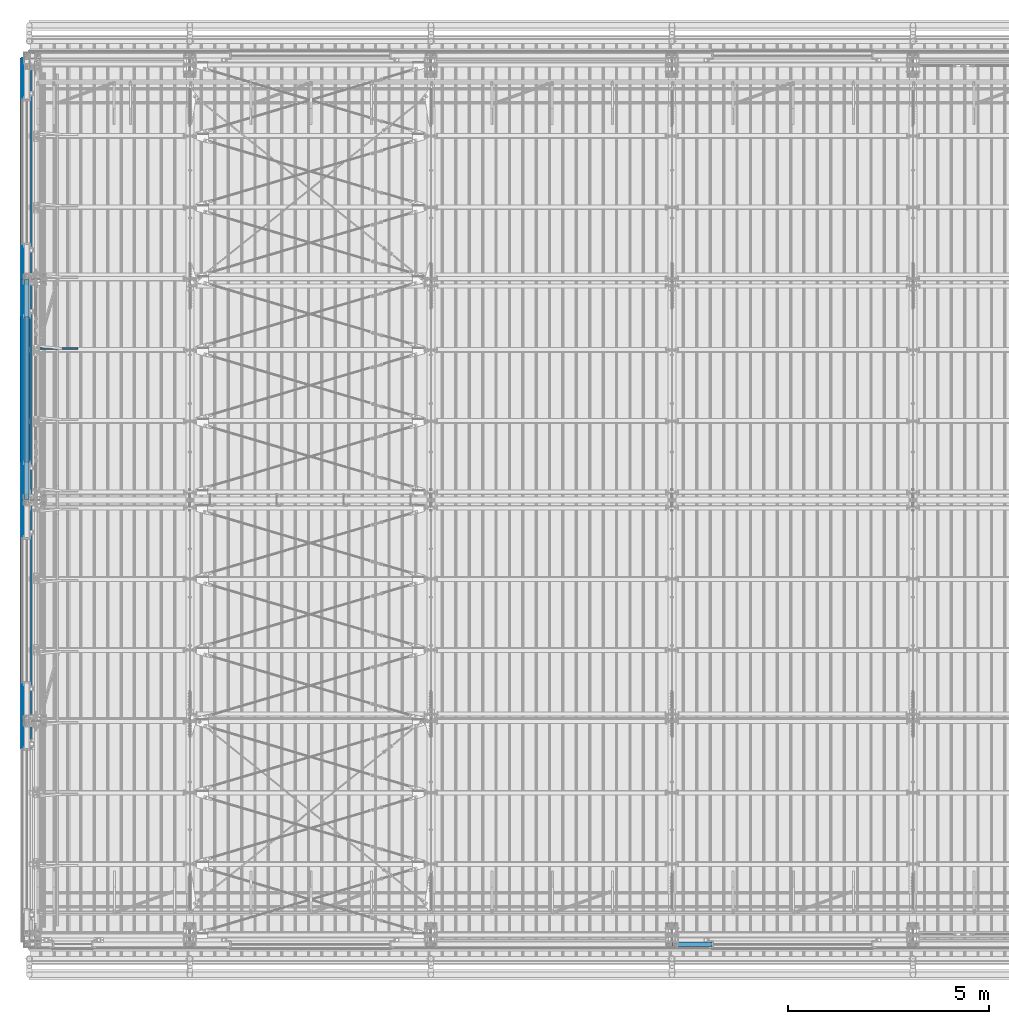
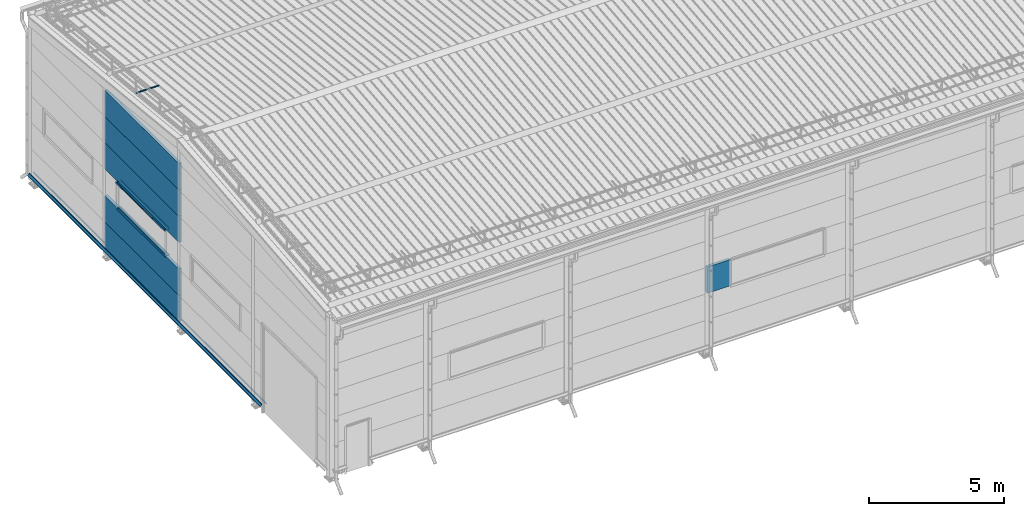
# One storey, part 40 of 709: 17 beams, 17 elements without a shape of their own.
"""IFC4 building model written with IfcOpenShell, lengths in millimetres."""

from ifc_helpers import new_model, si_unit, direction, frame, origin_with_axes, place, context, subcontext, project, spatial, line, indexed_curve, outline, extrude, material, element, aggregate, save


model = new_model("IFC4")

# Units and contexts
model_context = context("Model", 3, precision=0.2, world=origin_with_axes(), true_north=direction((0.0, 1.0)))
body_context = subcontext(model_context, "Body", "Model", "MODEL_VIEW")
ifc_project = project(units=[si_unit("LENGTHUNIT", "METRE", prefix="MILLI"), si_unit("AREAUNIT", "SQUARE_METRE"), si_unit("VOLUMEUNIT", "CUBIC_METRE"), si_unit("MASSUNIT", "GRAM", prefix="KILO"), si_unit("TIMEUNIT", "SECOND"), si_unit("PLANEANGLEUNIT", "RADIAN"), si_unit("SOLIDANGLEUNIT", "STERADIAN"), si_unit("THERMODYNAMICTEMPERATUREUNIT", "DEGREE_CELSIUS"), si_unit("LUMINOUSINTENSITYUNIT", "LUMEN")], contexts=[model_context])

# Site, building, storey
site_placement = place(None, origin_with_axes())
site = spatial("IfcSite", under=ifc_project, at=site_placement, CompositionType="ELEMENT")
building_placement = place(site_placement, origin_with_axes())
building = spatial("IfcBuilding", under=site, at=building_placement, Name="Undefined", CompositionType="ELEMENT")
storey_placement = place(building_placement, origin_with_axes())
storey = spatial("IfcBuildingStorey", under=building, at=storey_placement, Name="Undefined", CompositionType="ELEMENT", Elevation=0.0)

# Assembly, beam
assembly_1_placement = place(storey_placement, frame((220.0, 14773.4665, 8222.92296), z_axis=(0.0, 0.099503719, 0.9950371902), x_axis=(1.0, 0.0, 0.0)))
assembly_1 = element("IfcElementAssembly", 1, at=assembly_1_placement, inside=storey)
ifc_material_1 = material(Name="Steel_Undefined", Category="STEEL")
beam_1_placement = place(assembly_1_placement, origin_with_axes())
beam_1 = element("IfcBeam", 2, at=beam_1_placement, material=ifc_material_1, ObjectType="601", context=body_context, shape_type="SolidModel", body=[
    extrude(outline(indexed_curve([(-20.0, -25.0), (20.0, -25.0), (20.0, -22.5), (-17.5, -22.5), (-17.5, 22.5), (20.0, 22.5), (20.0, 25.0), (-20.0, 25.0)], segments=[line(1, 2, 3, 4, 5, 6, 7, 8, 1)])), frame((0.0, 0.0, 0.0), z_axis=(-1.0, 0.0, 0.0), x_axis=(0.0, 0.0, 1.0)), (0.0, 0.0, -1.0), 1000.0),
])
aggregate(assembly_1, [beam_1])

assembly_2_placement = place(storey_placement, frame((16010.0, -60.0, 3275.0), z_axis=(0.0, 0.0, -1.0), x_axis=(1.0, 0.0, 0.0)))
assembly_2 = element("IfcElementAssembly", 3, at=assembly_2_placement, inside=storey)
ifc_material_2 = material(Name="Insulation", Category="Insulation")
beam_2_placement = place(assembly_2_placement, origin_with_axes())
beam_2 = element("IfcBeam", 4, at=beam_2_placement, material=ifc_material_2, ObjectType="P-110", context=body_context, shape_type="SolidModel", body=[
    extrude(outline(indexed_curve([(-595.0, -60.0), (595.0, -60.0), (595.0, 60.0), (-595.0, 60.0)], segments=[line(1, 2, 3, 4, 1)])), frame((0.0, 0.0, 0.0), z_axis=(-1.0, 0.0, 0.0), x_axis=(0.0, 0.0, 1.0)), (0.0, 0.0, -1.0), 990.0),
])
aggregate(assembly_2, [beam_2])

assembly_3_placement = place(storey_placement, frame((-60.0, 11010.0, 895.0), z_axis=(0.0, 0.0, -1.0), x_axis=(0.0, 1.0, 0.0)))
assembly_3 = element("IfcElementAssembly", 5, at=assembly_3_placement, inside=storey)
beam_3_placement = place(assembly_3_placement, origin_with_axes())
beam_3 = element("IfcBeam", 6, at=beam_3_placement, material=ifc_material_2, ObjectType="P-135", context=body_context, shape_type="SolidModel", body=[
    extrude(outline(indexed_curve([(-595.0, -60.0), (595.0, -60.0), (595.0, 60.0), (-595.0, 60.0)], segments=[line(1, 2, 3, 4, 1)])), frame((0.0, 0.0, 0.0), z_axis=(-1.0, 0.0, 0.0), x_axis=(0.0, 0.0, 1.0)), (0.0, 0.0, -1.0), 5480.0),
])
aggregate(assembly_3, [beam_3])

assembly_4_placement = place(storey_placement, frame((-60.0, 11010.0, 2085.0), z_axis=(0.0, 0.0, -1.0), x_axis=(0.0, 1.0, 0.0)))
assembly_4 = element("IfcElementAssembly", 7, at=assembly_4_placement, inside=storey)
beam_4_placement = place(assembly_4_placement, origin_with_axes())
beam_4 = element("IfcBeam", 8, at=beam_4_placement, material=ifc_material_2, ObjectType="P-135", context=body_context, shape_type="SolidModel", body=[
    extrude(outline(indexed_curve([(-595.0, -60.0), (595.0, -60.0), (595.0, 60.0), (-595.0, 60.0)], segments=[line(1, 2, 3, 4, 1)])), frame((0.0, 0.0, 0.0), z_axis=(-1.0, 0.0, 0.0), x_axis=(0.0, 0.0, 1.0)), (0.0, 0.0, -1.0), 5480.0),
])
aggregate(assembly_4, [beam_4])

assembly_5_placement = place(storey_placement, frame((-60.0, 11010.0, 4465.0), z_axis=(0.0, 0.0, -1.0), x_axis=(0.0, 1.0, 0.0)))
assembly_5 = element("IfcElementAssembly", 9, at=assembly_5_placement, inside=storey)
beam_5_placement = place(assembly_5_placement, origin_with_axes())
beam_5 = element("IfcBeam", 10, at=beam_5_placement, material=ifc_material_2, ObjectType="P-135", context=body_context, shape_type="SolidModel", body=[
    extrude(outline(indexed_curve([(-595.0, -60.0), (595.0, -60.0), (595.0, 60.0), (-595.0, 60.0)], segments=[line(1, 2, 3, 4, 1)])), frame((0.0, 0.0, 0.0), z_axis=(-1.0, 0.0, 0.0), x_axis=(0.0, 0.0, 1.0)), (0.0, 0.0, -1.0), 5480.0),
])
aggregate(assembly_5, [beam_5])

assembly_6_placement = place(storey_placement, frame((-60.0, 11010.0, 5655.0), z_axis=(0.0, 0.0, -1.0), x_axis=(0.0, 1.0, 0.0)))
assembly_6 = element("IfcElementAssembly", 11, at=assembly_6_placement, inside=storey)
beam_6_placement = place(assembly_6_placement, origin_with_axes())
beam_6 = element("IfcBeam", 12, at=beam_6_placement, material=ifc_material_2, ObjectType="P-135", context=body_context, shape_type="SolidModel", body=[
    extrude(outline(indexed_curve([(-595.0, -60.0), (595.0, -60.0), (595.0, 60.0), (-595.0, 60.0)], segments=[line(1, 2, 3, 4, 1)])), frame((0.0, 0.0, 0.0), z_axis=(-1.0, 0.0, 0.0), x_axis=(0.0, 0.0, 1.0)), (0.0, 0.0, -1.0), 5480.0),
])
aggregate(assembly_6, [beam_6])

assembly_7_placement = place(storey_placement, frame((-60.0, 11010.0, 6845.0), z_axis=(0.0, 0.0, -1.0), x_axis=(0.0, 1.0, 0.0)))
assembly_7 = element("IfcElementAssembly", 13, at=assembly_7_placement, inside=storey)
beam_7_placement = place(assembly_7_placement, origin_with_axes())
beam_7 = element("IfcBeam", 14, at=beam_7_placement, material=ifc_material_2, ObjectType="P-135", context=body_context, shape_type="SolidModel", body=[
    extrude(outline(indexed_curve([(-595.0, -60.0), (595.0, -60.0), (595.0, 60.0), (-595.0, 60.0)], segments=[line(1, 2, 3, 4, 1)])), frame((0.0, 0.0, 0.0), z_axis=(-1.0, 0.0, 0.0), x_axis=(0.0, 0.0, 1.0)), (0.0, 0.0, -1.0), 5480.0),
])
aggregate(assembly_7, [beam_7])

assembly_8_placement = place(storey_placement, frame((-170.375, 4800.0, 370.0), z_axis=(1.0, 0.0, 0.0), x_axis=(0.0, 1.0, 0.0)))
assembly_8 = element("IfcElementAssembly", 15, at=assembly_8_placement, inside=storey)
beam_8_placement = place(assembly_8_placement, origin_with_axes())
beam_8 = element("IfcBeam", 16, at=beam_8_placement, material=ifc_material_1, context=body_context, shape_type="SolidModel", body=[
    extrude(outline(indexed_curve([(0.375, -20.0), (0.375, 19.25), (0.495, 19.25), (0.495, 5.0), (1.245, 5.0), (1.245, 20.0), (-0.375, 20.0), (-0.375, -19.68934), (-59.625, -78.93934), (-59.625, -118.93934), (-52.125, -105.94896), (-52.77452, -105.57396), (-58.875, -116.1403), (-58.875, -79.25)], segments=[line(1, 2, 3, 4, 5, 6, 7, 8, 9, 10, 11, 12, 13, 14, 1)])), frame((0.0, 0.0, 0.0), z_axis=(-1.0, 0.0, 0.0), x_axis=(0.0, 0.0, 1.0)), (0.0, 0.0, -1.0), 17200.0),
])
aggregate(assembly_8, [beam_8])

assembly_9_placement = place(storey_placement, frame((-155.0, 22000.0, 350.0), z_axis=(0.0, 0.0, -1.0), x_axis=(0.0, -1.0, 0.0)))
assembly_9 = element("IfcElementAssembly", 17, at=assembly_9_placement, inside=storey)
beam_9_placement = place(assembly_9_placement, origin_with_axes())
beam_9 = element("IfcBeam", 18, at=beam_9_placement, material=ifc_material_1, context=body_context, shape_type="SolidModel", body=[
    extrude(outline(indexed_curve([(-35.0, -1.0), (35.0, -1.0), (60.98076, 14.0), (59.98076, 15.73205), (34.4641, 1.0), (-35.0, 1.0)], segments=[line(1, 2, 3, 4, 5, 6, 1)])), frame((0.0, 0.0, 0.0), z_axis=(-1.0, 0.0, 0.0), x_axis=(0.0, 0.0, 1.0)), (0.0, 0.0, -1.0), 17200.0),
])
aggregate(assembly_9, [beam_9])

assembly_10_placement = place(storey_placement, frame((15.0, 4800.0, 350.0), z_axis=(0.0, 0.0, -1.0), x_axis=(0.0, 1.0, 0.0)))
assembly_10 = element("IfcElementAssembly", 19, at=assembly_10_placement, inside=storey)
beam_10_placement = place(assembly_10_placement, origin_with_axes())
beam_10 = element("IfcBeam", 20, at=beam_10_placement, material=ifc_material_1, context=body_context, shape_type="SolidModel", body=[
    extrude(outline(indexed_curve([(-45.0, -1.0), (45.0, -1.0), (45.0, 49.0), (43.0, 49.0), (43.0, 1.0), (-45.0, 1.0)], segments=[line(1, 2, 3, 4, 5, 6, 1)])), frame((0.0, 0.0, 0.0), z_axis=(-1.0, 0.0, 0.0), x_axis=(0.0, 0.0, 1.0)), (0.0, 0.0, -1.0), 17200.0),
])
aggregate(assembly_10, [beam_10])

assembly_11_placement = place(storey_placement, frame((-1.0, 15550.0, 2725.0), z_axis=(1.0, 0.0, 0.0), x_axis=(0.0, -1.0, 0.0)))
assembly_11 = element("IfcElementAssembly", 21, at=assembly_11_placement, inside=storey)
beam_11_placement = place(assembly_11_placement, origin_with_axes())
beam_11 = element("IfcBeam", 22, at=beam_11_placement, material=ifc_material_1, context=body_context, shape_type="SolidModel", body=[
    extrude(outline(indexed_curve([(-25.0, -1.0), (25.0, -1.0), (25.0, 99.0), (23.0, 99.0), (23.0, 1.0), (-25.0, 1.0)], segments=[line(1, 2, 3, 4, 5, 6, 1)])), frame((0.0, 0.0, 0.0), z_axis=(-1.0, 0.0, 0.0), x_axis=(0.0, 0.0, 1.0)), (0.0, 0.0, -1.0), 3600.0),
])
aggregate(assembly_11, [beam_11])

assembly_12_placement = place(storey_placement, frame((-60.0, 11950.0, 2680.0), z_axis=(1.0, 0.0, 0.0), x_axis=(0.0, 1.0, 0.0)))
assembly_12 = element("IfcElementAssembly", 23, at=assembly_12_placement, inside=storey)
beam_12_placement = place(assembly_12_placement, origin_with_axes())
beam_12 = element("IfcBeam", 24, at=beam_12_placement, material=ifc_material_1, context=body_context, shape_type="SolidModel", body=[
    extrude(outline(indexed_curve([(-70.0, -25.0), (-68.0, -25.0), (-68.0, 23.0), (68.0, 23.0), (68.0, -25.0), (70.0, -25.0), (70.0, 25.0), (-70.0, 25.0)], segments=[line(1, 2, 3, 4, 5, 6, 7, 8, 1)])), frame((0.0, 0.0, 0.0), z_axis=(-1.0, 0.0, 0.0), x_axis=(0.0, 0.0, 1.0)), (0.0, 0.0, -1.0), 3600.0),
])
aggregate(assembly_12, [beam_12])

assembly_13_placement = place(storey_placement, frame((-121.0, 11950.0, 2725.0), z_axis=(-1.0, 0.0, 0.0), x_axis=(0.0, 1.0, 0.0)))
assembly_13 = element("IfcElementAssembly", 25, at=assembly_13_placement, inside=storey)
beam_13_placement = place(assembly_13_placement, origin_with_axes())
beam_13 = element("IfcBeam", 26, at=beam_13_placement, material=ifc_material_1, context=body_context, shape_type="SolidModel", body=[
    extrude(outline(indexed_curve([(-25.0, -1.0), (25.0, -1.0), (25.0, 99.0), (23.0, 99.0), (23.0, 1.0), (-25.0, 1.0)], segments=[line(1, 2, 3, 4, 5, 6, 1)])), frame((0.0, 0.0, 0.0), z_axis=(-1.0, 0.0, 0.0), x_axis=(0.0, 0.0, 1.0)), (0.0, 0.0, -1.0), 3600.0),
])
aggregate(assembly_13, [beam_13])

assembly_14_placement = place(storey_placement, frame((-1.0, 11950.0, 3845.0), z_axis=(1.0, 0.0, 0.0), x_axis=(0.0, 1.0, 0.0)))
assembly_14 = element("IfcElementAssembly", 27, at=assembly_14_placement, inside=storey)
beam_14_placement = place(assembly_14_placement, origin_with_axes())
beam_14 = element("IfcBeam", 28, at=beam_14_placement, material=ifc_material_1, context=body_context, shape_type="SolidModel", body=[
    extrude(outline(indexed_curve([(-25.0, -1.0), (25.0, -1.0), (25.0, 99.0), (23.0, 99.0), (23.0, 1.0), (-25.0, 1.0)], segments=[line(1, 2, 3, 4, 5, 6, 1)])), frame((0.0, 0.0, 0.0), z_axis=(-1.0, 0.0, 0.0), x_axis=(0.0, 0.0, 1.0)), (0.0, 0.0, -1.0), 3600.0),
])
aggregate(assembly_14, [beam_14])

assembly_15_placement = place(storey_placement, frame((-60.0, 15550.0, 3890.0), z_axis=(1.0, 0.0, 0.0), x_axis=(0.0, -1.0, 0.0)))
assembly_15 = element("IfcElementAssembly", 29, at=assembly_15_placement, inside=storey)
beam_15_placement = place(assembly_15_placement, origin_with_axes())
beam_15 = element("IfcBeam", 30, at=beam_15_placement, material=ifc_material_1, context=body_context, shape_type="SolidModel", body=[
    extrude(outline(indexed_curve([(-70.0, -25.0), (-68.0, -25.0), (-68.0, 23.0), (68.0, 23.0), (68.0, -25.0), (70.0, -25.0), (70.0, 25.0), (-70.0, 25.0)], segments=[line(1, 2, 3, 4, 5, 6, 7, 8, 1)])), frame((0.0, 0.0, 0.0), z_axis=(-1.0, 0.0, 0.0), x_axis=(0.0, 0.0, 1.0)), (0.0, 0.0, -1.0), 3600.0),
])
aggregate(assembly_15, [beam_15])

assembly_16_placement = place(storey_placement, frame((-121.0, 15550.0, 3845.0), z_axis=(-1.0, 0.0, 0.0), x_axis=(0.0, -1.0, 0.0)))
assembly_16 = element("IfcElementAssembly", 31, at=assembly_16_placement, inside=storey)
beam_16_placement = place(assembly_16_placement, origin_with_axes())
beam_16 = element("IfcBeam", 32, at=beam_16_placement, material=ifc_material_1, context=body_context, shape_type="SolidModel", body=[
    extrude(outline(indexed_curve([(-25.0, -1.0), (25.0, -1.0), (25.0, 99.0), (23.0, 99.0), (23.0, 1.0), (-25.0, 1.0)], segments=[line(1, 2, 3, 4, 5, 6, 1)])), frame((0.0, 0.0, 0.0), z_axis=(-1.0, 0.0, 0.0), x_axis=(0.0, 0.0, 1.0)), (0.0, 0.0, -1.0), 3600.0),
])
aggregate(assembly_16, [beam_16])

assembly_17_placement = place(storey_placement, frame((-171.0, 15550.0, 3830.0), z_axis=(-1.0, 0.0, 0.0), x_axis=(0.0, -1.0, 0.0)))
assembly_17 = element("IfcElementAssembly", 33, at=assembly_17_placement, inside=storey)
beam_17_placement = place(assembly_17_placement, origin_with_axes())
beam_17 = element("IfcBeam", 34, at=beam_17_placement, material=ifc_material_1, context=body_context, shape_type="SolidModel", body=[
    extrude(outline(indexed_curve([(-10.0, -1.0), (10.0, -1.0), (10.0, 49.0), (8.0, 49.0), (8.0, 1.0), (-10.0, 1.0)], segments=[line(1, 2, 3, 4, 5, 6, 1)])), frame((0.0, 0.0, 0.0), z_axis=(-1.0, 0.0, 0.0), x_axis=(0.0, 0.0, 1.0)), (0.0, 0.0, -1.0), 3600.0),
])
aggregate(assembly_17, [beam_17])

save(model, "model.ifc")
